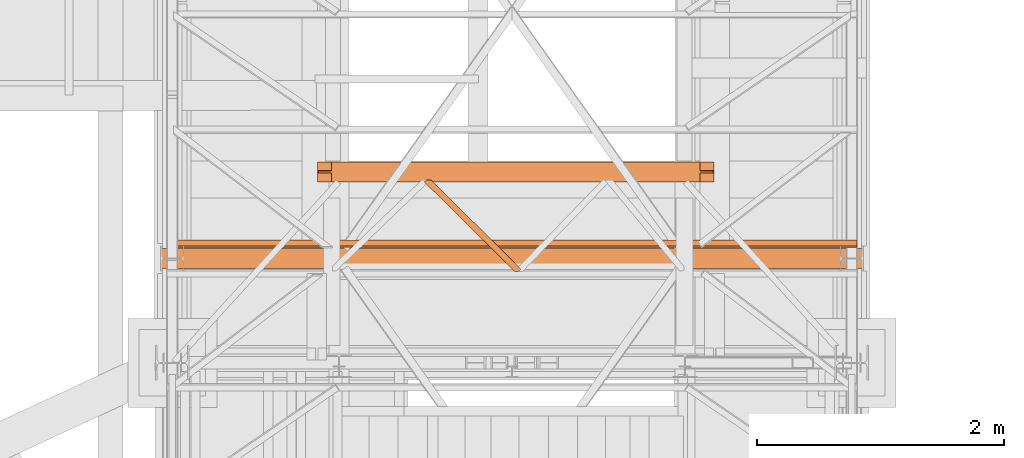
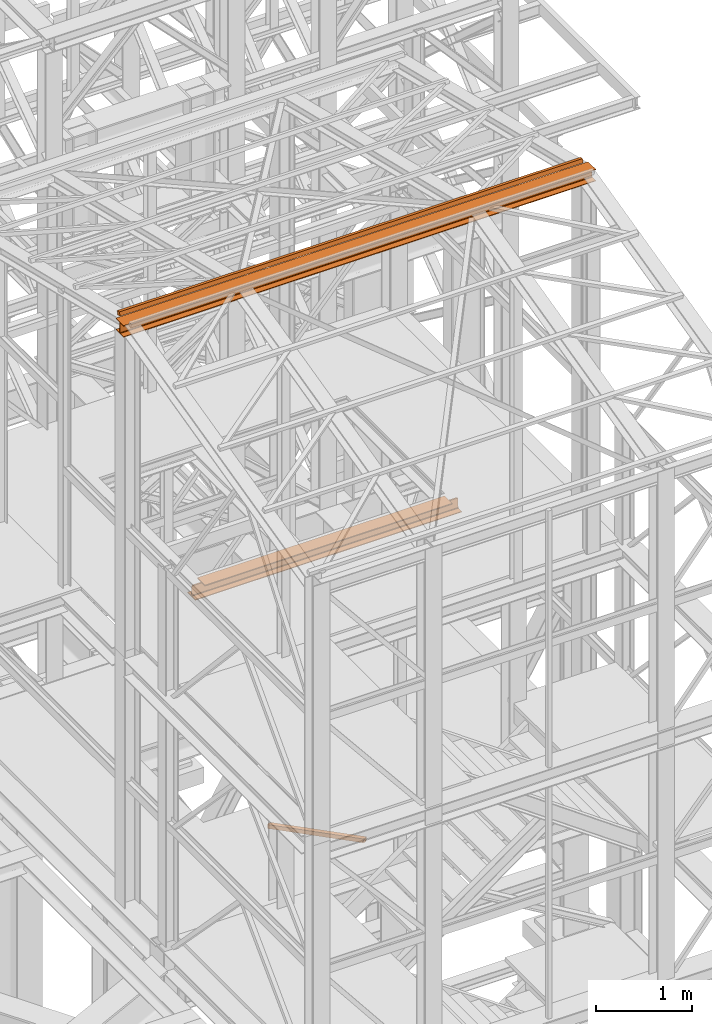
# One storey, part 62 of 208: 4 proxies.
"""IFC2X3 building model written with IfcOpenShell, lengths in millimetres."""

from ifc_helpers import new_model, entity, si_unit, converted_unit, frame, origin, origin_with_axes, place, context, subcontext, project, spatial, faceted_brep, element, save


model = new_model("IFC2X3")

# Units and contexts
model_context = context("Model", 3, precision=1e-05, world=origin())
plan_context = context("Plan", 3, precision=1e-05, world=origin())
body_context = subcontext(model_context, "Body", "Model", "MODEL_VIEW")
ifc_project = project(units=[si_unit("LENGTHUNIT", "METRE", prefix="MILLI"), converted_unit("PLANEANGLEUNIT", "DEGREE", entity("IfcPlaneAngleMeasure", 0.0174532925199433), si_unit("PLANEANGLEUNIT", "RADIAN"), dimensions=[0, 0, 0, 0, 0, 0, 0]), si_unit("AREAUNIT", "SQUARE_METRE"), si_unit("VOLUMEUNIT", "CUBIC_METRE")], contexts=[model_context, plan_context])

# Building, storey
building_placement = place(None, origin())
building = spatial("IfcBuilding", under=ifc_project, at=building_placement, CompositionType="COMPLEX")
storey_placement = place(building_placement, origin_with_axes())
storey = spatial("IfcBuildingStorey", under=building, at=storey_placement, Name="Geschoss", CompositionType="ELEMENT")

# Proxies
proxy_1_placement = place(storey_placement, frame((2372.004968677677, -20596.8503087619, 8332.989992072577), z_axis=(0.0, 0.0, 1.0), x_axis=(1.0, 0.0, 0.0)))
element("IfcBuildingElementProxy", 1, at=proxy_1_placement, inside=storey, context=body_context, shape_type="Brep", body=[
    faceted_brep([(3212.509999701978, 83.01000568851669, 119.0100101923945), (3212.509999701978, 83.01000568851669, 24.01000393390677), (3212.509999701978, 84.56379586666662, 16.24682677745841), (3212.509999701978, 90.24683052509863, 10.5637921190264), (3212.509999701978, 98.01000675022442, 9.010003337860326), (3212.509999701978, 160.0100113248809, 9.010003337860326), (3212.509999701978, 160.0100113248809, 0.01000000000021828), (3212.509999701978, 0.00999999999839929, 0.01000000000021828), (3212.509999701978, 0.00999999999839929, 9.010003337860326), (3212.509999701978, 62.01000457465489, 9.010003337860326), (3212.509999701978, 69.77318079978068, 10.5637921190264), (3212.509999701978, 75.45621545821268, 16.24682677745841), (3212.509999701978, 77.01000563636262, 24.01000393390677), (3212.509999701978, 77.01000563636262, 119.0100101923945), (3096.259995082618, 0.00999999999839929, 152.0100100135805), (116.2600046193611, 0.01000000000203727, 152.0100100135805), (116.2600046193611, 160.0100113248845, 152.0100100135805), (3096.259995082618, 160.0100113248809, 152.0100100135805), (3096.259995082618, 160.0100113248809, 152.0100100135805), (116.2600046193611, 160.0100113248845, 152.0100100135805), (116.2600046193611, 160.0100113248845, 143.0100066757204), (3096.259995082618, 160.0100113248809, 143.0100066757204), (3096.259995082618, 160.0100113248809, 143.0100066757204), (116.2600046193611, 160.0100113248845, 143.0100066757204), (116.2600046193611, 98.01000675022806, 143.0100066757204), (3096.259995082618, 98.01000675022442, 143.0100066757204), (3096.259995082618, 98.01000675022442, 143.0100066757204), (116.2600046193611, 98.01000675022806, 143.0100066757204), (116.2600046193611, 90.24683052510227, 141.4562178945544), (3096.259995082618, 90.24683052509863, 141.4562178945544), (3096.259995082618, 90.24683052509863, 141.4562178945544), (116.2600046193611, 90.24683052510227, 141.4562178945544), (116.2600046193611, 88.80062067717517, 140.0100080466273), (21.01000157952421, 88.80062067717517, 140.0100080466273), (10.14155560940617, 86.6253193637749, 137.834706733227), (8.080032594925797, 84.56379586667026, 135.7731832361224), (3204.439967107053, 84.56379586666662, 135.7731832361224), (3202.378444092573, 86.62531936377127, 137.834706733227), (3191.509998122455, 88.80062067717154, 140.0100080466273), (3096.259995082618, 88.80062067717154, 140.0100080466273), (3204.439967107053, 84.56379586666662, 135.7731832361224), (8.080032594925797, 84.56379586667026, 135.7731832361224), (2.185305970014269, 83.38397287828047, 129.87845523119), (1.811338905195044, 83.01000568852032, 128.0100098049643), (3210.708660796785, 83.01000568851669, 128.0100098049643), (3210.334693731965, 83.38397287828047, 129.87845523119), (3212.509999701978, 83.01000568851669, 24.01000393390677), (3212.509999701978, 83.01000568851669, 119.0100101923945), (3210.708660796785, 83.01000568851669, 128.0100098049643), (1.811338905195044, 83.01000568852032, 128.0100098049643), (0.01000000000203727, 83.01000568852032, 119.0100101923945), (0.01000000000203727, 83.01000568852032, 24.01000393390677), (3212.509999701978, 84.56379586666662, 16.24682677745841), (3212.509999701978, 83.01000568851669, 24.01000393390677), (0.01000000000203727, 83.01000568852032, 24.01000393390677), (0.01000000000203727, 84.56379586667026, 16.24682677745841), (3212.509999701978, 90.24683052509863, 10.5637921190264), (3212.509999701978, 84.56379586666662, 16.24682677745841), (0.01000000000203727, 84.56379586667026, 16.24682677745841), (0.01000000000203727, 90.24683052510227, 10.5637921190264), (3212.509999701978, 98.01000675022442, 9.010003337860326), (3212.509999701978, 90.24683052509863, 10.5637921190264), (0.01000000000203727, 90.24683052510227, 10.5637921190264), (0.01000000000203727, 98.01000675022806, 9.010003337860326), (3212.509999701978, 160.0100113248809, 9.010003337860326), (3212.509999701978, 98.01000675022442, 9.010003337860326), (0.01000000000203727, 98.01000675022806, 9.010003337860326), (0.01000000000203727, 160.0100113248845, 9.010003337860326), (3212.509999701978, 160.0100113248809, 0.01000000000021828), (3212.509999701978, 160.0100113248809, 9.010003337860326), (0.01000000000203727, 160.0100113248845, 9.010003337860326), (0.01000000000203727, 160.0100113248845, 0.01000000000021828), (3212.509999701978, 0.00999999999839929, 0.01000000000021828), (3212.509999701978, 160.0100113248809, 0.01000000000021828), (0.01000000000203727, 160.0100113248845, 0.01000000000021828), (0.01000000000021828, 0.01000000000203727, 0.01000000000021828), (3212.509999701978, 0.00999999999839929, 9.010003337860326), (3212.509999701978, 0.00999999999839929, 0.01000000000021828), (0.01000000000021828, 0.01000000000203727, 0.01000000000021828), (0.01000000000203727, 0.01000000000203727, 9.010003337860326), (3212.509999701978, 62.01000457465489, 9.010003337860326), (3212.509999701978, 0.00999999999839929, 9.010003337860326), (0.01000000000203727, 0.01000000000203727, 9.010003337860326), (0.01000000000203727, 62.01000457465852, 9.010003337860326), (3212.509999701978, 69.77318079978068, 10.5637921190264), (3212.509999701978, 62.01000457465489, 9.010003337860326), (0.01000000000203727, 62.01000457465852, 9.010003337860326), (0.01000000000203727, 69.77318079978431, 10.5637921190264), (3212.509999701978, 75.45621545821268, 16.24682677745841), (3212.509999701978, 69.77318079978068, 10.5637921190264), (0.01000000000203727, 69.77318079978431, 10.5637921190264), (0.01000000000203727, 75.45621545821632, 16.24682677745841), (3212.509999701978, 77.01000563636262, 24.01000393390677), (3212.509999701978, 75.45621545821268, 16.24682677745841), (0.01000000000203727, 75.45621545821632, 16.24682677745841), (0.01000000000203727, 77.01000563636626, 24.01000393390677), (3212.509999701978, 77.01000563636262, 119.0100101923945), (3212.509999701978, 77.01000563636262, 24.01000393390677), (0.01000000000203727, 77.01000563636626, 24.01000393390677), (0.01000000000203727, 77.01000563636626, 119.0100101923945), (1.811338905195044, 77.01000563636626, 128.0100098049643), (3210.708660796784, 77.01000563636262, 128.0100098049643), (3210.708660796784, 77.01000563636262, 128.0100098049643), (1.811338905195044, 77.01000563636626, 128.0100098049643), (2.185305970014269, 76.63603844660247, 129.87845523119), (8.080032594926706, 75.45621545821632, 135.7731832361224), (3204.439967107053, 75.45621545821268, 135.7731832361224), (3210.334693731965, 76.63603844660247, 129.87845523119), (3204.439967107053, 75.45621545821268, 135.7731832361224), (8.080032594926706, 75.45621545821632, 135.7731832361224), (10.14155560940617, 73.39469196110804, 137.834706733227), (21.01000157952421, 71.21939064770777, 140.0100080466273), (116.2600046193611, 71.21939064770777, 140.0100080466273), (116.2600046193611, 69.77318079978431, 141.4562178945544), (3096.259995082618, 69.77318079978068, 141.4562178945544), (3096.259995082618, 71.21939064770777, 140.0100080466273), (3191.509998122455, 71.21939064770777, 140.0100080466273), (3202.378444092573, 73.39469196110804, 137.834706733227), (3096.259995082618, 69.77318079978068, 141.4562178945544), (116.2600046193611, 69.77318079978431, 141.4562178945544), (116.2600046193611, 62.01000457465852, 143.0100066757204), (3096.259995082618, 62.01000457465489, 143.0100066757204), (3096.259995082618, 62.01000457465489, 143.0100066757204), (116.2600046193611, 62.01000457465852, 143.0100066757204), (116.2600046193611, 0.01000000000203727, 143.0100066757204), (3096.259995082618, 0.00999999999839929, 143.0100066757204), (3096.259995082618, 0.00999999999839929, 143.0100066757204), (116.2600046193611, 0.01000000000203727, 143.0100066757204), (116.2600046193611, 0.01000000000203727, 152.0100100135805), (3096.259995082618, 0.00999999999839929, 152.0100100135805), (0.01000000000203727, 77.01000563636626, 119.0100101923945), (0.01000000000203727, 77.01000563636626, 24.01000393390677), (0.01000000000203727, 75.45621545821632, 16.24682677745841), (0.01000000000203727, 69.77318079978431, 10.5637921190264), (0.01000000000203727, 62.01000457465852, 9.010003337860326), (0.01000000000203727, 0.01000000000203727, 9.010003337860326), (0.01000000000021828, 0.01000000000203727, 0.01000000000021828), (0.01000000000203727, 160.0100113248845, 0.01000000000021828), (0.01000000000203727, 160.0100113248845, 9.010003337860326), (0.01000000000203727, 98.01000675022806, 9.010003337860326), (0.01000000000203727, 90.24683052510227, 10.5637921190264), (0.01000000000203727, 84.56379586667026, 16.24682677745841), (0.01000000000203727, 83.01000568852032, 24.01000393390677), (0.01000000000203727, 83.01000568852032, 119.0100101923945), (3096.259995082618, 160.0100113248809, 152.0100100135805), (3096.259995082618, 160.0100113248809, 143.0100066757204), (3096.259995082618, 98.01000675022442, 143.0100066757204), (3096.259995082618, 90.24683052509863, 141.4562178945544), (3096.259995082618, 88.80062067717154, 140.0100080466273), (3096.259995082618, 71.21939064770777, 140.0100080466273), (3096.259995082618, 69.77318079978068, 141.4562178945544), (3096.259995082618, 62.01000457465489, 143.0100066757204), (3096.259995082618, 0.00999999999839929, 143.0100066757204), (3096.259995082618, 0.00999999999839929, 152.0100100135805), (3096.259995082618, 88.80062067717154, 140.0100080466273), (3191.509998122455, 88.80062067717154, 140.0100080466273), (3191.509998122455, 71.21939064770777, 140.0100080466273), (3096.259995082618, 71.21939064770777, 140.0100080466273), (3191.509998122455, 88.80062067717154, 140.0100080466273), (3202.378444092573, 86.62531936377127, 137.834706733227), (3202.378444092573, 73.39469196110804, 137.834706733227), (3191.509998122455, 71.21939064770777, 140.0100080466273), (3202.378444092573, 86.62531936377127, 137.834706733227), (3204.439967107053, 84.56379586666662, 135.7731832361224), (3210.334693731965, 83.38397287828047, 129.87845523119), (3210.334693731965, 76.63603844660247, 129.87845523119), (3204.439967107053, 75.45621545821268, 135.7731832361224), (3202.378444092573, 73.39469196110804, 137.834706733227), (3210.334693731965, 83.38397287828047, 129.87845523119), (3210.708660796785, 83.01000568851669, 128.0100098049643), (3212.509999701978, 83.01000568851669, 119.0100101923945), (3212.509999701978, 77.01000563636262, 119.0100101923945), (3210.708660796784, 77.01000563636262, 128.0100098049643), (3210.334693731965, 76.63603844660247, 129.87845523119), (0.01000000000203727, 83.01000568852032, 119.0100101923945), (1.811338905195044, 83.01000568852032, 128.0100098049643), (2.185305970014269, 83.38397287828047, 129.87845523119), (2.185305970014269, 76.63603844660247, 129.87845523119), (1.811338905195044, 77.01000563636626, 128.0100098049643), (0.01000000000203727, 77.01000563636626, 119.0100101923945), (2.185305970014269, 83.38397287828047, 129.87845523119), (8.080032594925797, 84.56379586667026, 135.7731832361224), (10.14155560940617, 86.6253193637749, 137.834706733227), (10.14155560940617, 73.39469196110804, 137.834706733227), (8.080032594926706, 75.45621545821632, 135.7731832361224), (2.185305970014269, 76.63603844660247, 129.87845523119), (10.14155560940617, 86.6253193637749, 137.834706733227), (21.01000157952421, 88.80062067717517, 140.0100080466273), (21.01000157952421, 71.21939064770777, 140.0100080466273), (10.14155560940617, 73.39469196110804, 137.834706733227), (21.01000157952421, 88.80062067717517, 140.0100080466273), (116.2600046193611, 88.80062067717517, 140.0100080466273), (116.2600046193611, 71.21939064770777, 140.0100080466273), (21.01000157952421, 71.21939064770777, 140.0100080466273), (116.2600046193611, 88.80062067717517, 140.0100080466273), (116.2600046193611, 90.24683052510227, 141.4562178945544), (116.2600046193611, 98.01000675022806, 143.0100066757204), (116.2600046193611, 160.0100113248845, 143.0100066757204), (116.2600046193611, 160.0100113248845, 152.0100100135805), (116.2600046193611, 0.01000000000203727, 152.0100100135805), (116.2600046193611, 0.01000000000203727, 143.0100066757204), (116.2600046193611, 62.01000457465852, 143.0100066757204), (116.2600046193611, 69.77318079978431, 141.4562178945544), (116.2600046193611, 71.21939064770777, 140.0100080466273)], [[[0, 1, 2, 3, 4, 5, 6, 7, 8, 9, 10, 11, 12, 13]], [[14, 15, 16, 17]], [[18, 19, 20, 21]], [[22, 23, 24, 25]], [[26, 27, 28, 29]], [[30, 31, 32, 33, 34, 35, 36, 37, 38, 39]], [[40, 41, 42, 43, 44, 45]], [[46, 47, 48, 49, 50, 51]], [[52, 53, 54, 55]], [[56, 57, 58, 59]], [[60, 61, 62, 63]], [[64, 65, 66, 67]], [[68, 69, 70, 71]], [[72, 73, 74, 75]], [[76, 77, 78, 79]], [[80, 81, 82, 83]], [[84, 85, 86, 87]], [[88, 89, 90, 91]], [[92, 93, 94, 95]], [[96, 97, 98, 99, 100, 101]], [[102, 103, 104, 105, 106, 107]], [[108, 109, 110, 111, 112, 113, 114, 115, 116, 117]], [[118, 119, 120, 121]], [[122, 123, 124, 125]], [[126, 127, 128, 129]], [[130, 131, 132, 133, 134, 135, 136, 137, 138, 139, 140, 141, 142, 143]], [[144, 145, 146, 147, 148, 149, 150, 151, 152, 153]], [[154, 155, 156, 157]], [[158, 159, 160, 161]], [[162, 163, 164, 165, 166, 167]], [[168, 169, 170, 171, 172, 173]], [[174, 175, 176, 177, 178, 179]], [[180, 181, 182, 183, 184, 185]], [[186, 187, 188, 189]], [[190, 191, 192, 193]], [[194, 195, 196, 197, 198, 199, 200, 201, 202, 203]]], orient=[[False], [False], [False], [False], [False], [False], [False], [False], [False], [False], [False], [False], [False], [False], [False], [False], [False], [False], [False], [False], [False], [False], [False], [False], [False], [False], [False], [False], [False], [False], [False], [False], [False], [False], [False], [False]]),
])
proxy_2_placement = place(storey_placement, frame((1157.254971121463, -21129.0126483825, 12689.02228571494), z_axis=(0.0, 0.0, 1.0), x_axis=(1.0, 0.0, 0.0)))
element("IfcBuildingElementProxy", 2, at=proxy_2_placement, inside=storey, context=body_context, shape_type="Brep", body=[
    faceted_brep([(5582.010002264973, 11.80406569683692, 60.39315927079588), (5582.010002264973, 60.39315927079224, 48.59909357395736), (5582.010002264973, 48.59909357395372, 0.01000000000021828), (5582.010002264973, 0.00999999999839929, 11.80406569683873), (0.01000000000021828, 60.39315927079224, 48.59909357395736), (0.01000000000021828, 11.80406569683692, 60.39315927079588), (0.01000000000021828, 0.00999999999839929, 11.80406569683873), (0.01000000000021828, 48.59909357395372, 0.01000000000021828), (5582.010002264973, 60.39315927079224, 48.59909357395736), (5582.010002264973, 11.80406569683692, 60.39315927079588), (0.01000000000021828, 11.80406569683692, 60.39315927079588), (0.01000000000021828, 60.39315927079224, 48.59909357395736), (5582.010002264973, 48.59909357395372, 0.01000000000021828), (5582.010002264973, 60.39315927079224, 48.59909357395736), (0.01000000000021828, 60.39315927079224, 48.59909357395736), (0.01000000000021828, 48.59909357395372, 0.01000000000021828), (5582.010002264973, 0.00999999999839929, 11.80406569683873), (5582.010002264973, 48.59909357395372, 0.01000000000021828), (0.01000000000021828, 48.59909357395372, 0.01000000000021828), (0.01000000000021828, 0.00999999999839929, 11.80406569683873), (5582.010002264973, 11.80406569683692, 60.39315927079588), (5582.010002264973, 0.00999999999839929, 11.80406569683873), (0.01000000000021828, 0.00999999999839929, 11.80406569683873), (0.01000000000021828, 11.80406569683692, 60.39315927079588)], [[[0, 1, 2, 3]], [[4, 5, 6, 7]], [[8, 9, 10, 11]], [[12, 13, 14, 15]], [[16, 17, 18, 19]], [[20, 21, 22, 23]]], orient=[[False], [False], [False], [False], [False], [False]]),
])
proxy_3_placement = place(storey_placement, frame((1103.25496227017, -21297.57439598033, 12550.89453781338), z_axis=(0.0, 0.0, 1.0), x_axis=(1.0, 0.0, 0.0)))
element("IfcBuildingElementProxy", 3, at=proxy_3_placement, inside=storey, context=body_context, shape_type="Brep", body=[
    faceted_brep([(5690.010012516976, 0.00999999999839929, 152.0100100135805), (5690.010012516976, 160.0100113248809, 152.0100100135805), (5690.010012516976, 160.0100113248809, 143.0100066757204), (5690.010012516976, 98.01000675022442, 143.0100066757204), (5690.010012516976, 90.24683052509863, 141.4562178945544), (5690.010012516976, 84.56379586666662, 135.7731832361224), (5690.010012516976, 83.01000568851669, 128.0100098049643), (5690.010012516976, 83.01000568851669, 24.01000393390677), (5690.010012516976, 84.56379586666662, 16.24682677745841), (5690.010012516976, 90.24683052509863, 10.5637921190264), (5690.010012516976, 98.01000675022442, 9.010003337860326), (5690.010012516976, 160.0100113248809, 9.010003337860326), (5690.010012516976, 160.0100113248809, 0.01000000000021828), (5690.010012516976, 0.00999999999839929, 0.01000000000021828), (5690.010012516976, 0.00999999999839929, 9.010003337860326), (5690.010012516976, 62.01000457465489, 9.010003337860326), (5690.010012516976, 69.77318079978068, 10.5637921190264), (5690.010012516976, 75.45621545821268, 16.24682677745841), (5690.010012516976, 77.01000563636262, 24.01000393390677), (5690.010012516976, 77.01000563636262, 128.0100098049643), (5690.010012516976, 75.45621545821268, 135.7731832361224), (5690.010012516976, 69.77318079978068, 141.4562178945544), (5690.010012516976, 62.01000457465489, 143.0100066757204), (5690.010012516976, 0.00999999999839929, 143.0100066757204), (5690.010012516976, 160.0100113248809, 152.0100100135805), (5690.010012516976, 0.00999999999839929, 152.0100100135805), (0.01000000000021828, 0.00999999999839929, 152.0100100135805), (0.01000000000021828, 160.0100113248809, 152.0100100135805), (5690.010012516976, 160.0100113248809, 143.0100066757204), (5690.010012516976, 160.0100113248809, 152.0100100135805), (0.01000000000021828, 160.0100113248809, 152.0100100135805), (0.01000000000021828, 160.0100113248809, 143.0100066757204), (5690.010012516976, 98.01000675022442, 143.0100066757204), (5690.010012516976, 160.0100113248809, 143.0100066757204), (0.01000000000021828, 160.0100113248809, 143.0100066757204), (0.01000000000021828, 98.01000675022442, 143.0100066757204), (5690.010012516976, 90.24683052509863, 141.4562178945544), (5690.010012516976, 98.01000675022442, 143.0100066757204), (0.01000000000021828, 98.01000675022442, 143.0100066757204), (0.01000000000021828, 90.24683052509863, 141.4562178945544), (5690.010012516976, 84.56379586666662, 135.7731832361224), (5690.010012516976, 90.24683052509863, 141.4562178945544), (0.01000000000021828, 90.24683052509863, 141.4562178945544), (0.01000000000021828, 84.56379586666662, 135.7731832361224), (5690.010012516976, 83.01000568851669, 128.0100098049643), (5690.010012516976, 84.56379586666662, 135.7731832361224), (0.01000000000021828, 84.56379586666662, 135.7731832361224), (0.01000000000021828, 83.01000568851669, 128.0100098049643), (5690.010012516976, 83.01000568851669, 24.01000393390677), (5690.010012516976, 83.01000568851669, 128.0100098049643), (0.01000000000021828, 83.01000568851669, 128.0100098049643), (0.01000000000021828, 83.01000568851669, 24.01000393390677), (5690.010012516976, 84.56379586666662, 16.24682677745841), (5690.010012516976, 83.01000568851669, 24.01000393390677), (0.01000000000021828, 83.01000568851669, 24.01000393390677), (0.01000000000021828, 84.56379586666662, 16.24682677745841), (5690.010012516976, 90.24683052509863, 10.5637921190264), (5690.010012516976, 84.56379586666662, 16.24682677745841), (0.01000000000021828, 84.56379586666662, 16.24682677745841), (0.01000000000021828, 90.24683052509863, 10.5637921190264), (5690.010012516976, 98.01000675022442, 9.010003337860326), (5690.010012516976, 90.24683052509863, 10.5637921190264), (0.01000000000021828, 90.24683052509863, 10.5637921190264), (0.01000000000021828, 98.01000675022442, 9.010003337860326), (5690.010012516976, 160.0100113248809, 9.010003337860326), (5690.010012516976, 98.01000675022442, 9.010003337860326), (0.01000000000021828, 98.01000675022442, 9.010003337860326), (0.01000000000021828, 160.0100113248809, 9.010003337860326), (5690.010012516976, 160.0100113248809, 0.01000000000021828), (5690.010012516976, 160.0100113248809, 9.010003337860326), (0.01000000000021828, 160.0100113248809, 9.010003337860326), (0.01000000000021828, 160.0100113248809, 0.01000000000021828), (5690.010012516976, 0.00999999999839929, 0.01000000000021828), (5690.010012516976, 160.0100113248809, 0.01000000000021828), (0.01000000000021828, 160.0100113248809, 0.01000000000021828), (0.01000000000021828, 0.00999999999839929, 0.01000000000021828), (5690.010012516976, 0.00999999999839929, 9.010003337860326), (5690.010012516976, 0.00999999999839929, 0.01000000000021828), (0.01000000000021828, 0.00999999999839929, 0.01000000000021828), (0.01000000000021828, 0.00999999999839929, 9.010003337860326), (5690.010012516976, 62.01000457465489, 9.010003337860326), (5690.010012516976, 0.00999999999839929, 9.010003337860326), (0.01000000000021828, 0.00999999999839929, 9.010003337860326), (0.01000000000021828, 62.01000457465489, 9.010003337860326), (5690.010012516976, 69.77318079978068, 10.5637921190264), (5690.010012516976, 62.01000457465489, 9.010003337860326), (0.01000000000021828, 62.01000457465489, 9.010003337860326), (0.01000000000021828, 69.77318079978068, 10.5637921190264), (5690.010012516976, 75.45621545821268, 16.24682677745841), (5690.010012516976, 69.77318079978068, 10.5637921190264), (0.01000000000021828, 69.77318079978068, 10.5637921190264), (0.01000000000021828, 75.45621545821268, 16.24682677745841), (5690.010012516976, 77.01000563636262, 24.01000393390677), (5690.010012516976, 75.45621545821268, 16.24682677745841), (0.01000000000021828, 75.45621545821268, 16.24682677745841), (0.01000000000021828, 77.01000563636262, 24.01000393390677), (5690.010012516976, 77.01000563636262, 128.0100098049643), (5690.010012516976, 77.01000563636262, 24.01000393390677), (0.01000000000021828, 77.01000563636262, 24.01000393390677), (0.01000000000021828, 77.01000563636262, 128.0100098049643), (5690.010012516976, 75.45621545821268, 135.7731832361224), (5690.010012516976, 77.01000563636262, 128.0100098049643), (0.01000000000021828, 77.01000563636262, 128.0100098049643), (0.01000000000021828, 75.45621545821268, 135.7731832361224), (5690.010012516976, 69.77318079978068, 141.4562178945544), (5690.010012516976, 75.45621545821268, 135.7731832361224), (0.01000000000021828, 75.45621545821268, 135.7731832361224), (0.01000000000021828, 69.77318079978068, 141.4562178945544), (5690.010012516976, 62.01000457465489, 143.0100066757204), (5690.010012516976, 69.77318079978068, 141.4562178945544), (0.01000000000021828, 69.77318079978068, 141.4562178945544), (0.01000000000021828, 62.01000457465489, 143.0100066757204), (5690.010012516976, 0.00999999999839929, 143.0100066757204), (5690.010012516976, 62.01000457465489, 143.0100066757204), (0.01000000000021828, 62.01000457465489, 143.0100066757204), (0.01000000000021828, 0.00999999999839929, 143.0100066757204), (5690.010012516976, 0.00999999999839929, 152.0100100135805), (5690.010012516976, 0.00999999999839929, 143.0100066757204), (0.01000000000021828, 0.00999999999839929, 143.0100066757204), (0.01000000000021828, 0.00999999999839929, 152.0100100135805), (0.01000000000021828, 0.00999999999839929, 152.0100100135805), (0.01000000000021828, 0.00999999999839929, 143.0100066757204), (0.01000000000021828, 62.01000457465489, 143.0100066757204), (0.01000000000021828, 69.77318079978068, 141.4562178945544), (0.01000000000021828, 75.45621545821268, 135.7731832361224), (0.01000000000021828, 77.01000563636262, 128.0100098049643), (0.01000000000021828, 77.01000563636262, 24.01000393390677), (0.01000000000021828, 75.45621545821268, 16.24682677745841), (0.01000000000021828, 69.77318079978068, 10.5637921190264), (0.01000000000021828, 62.01000457465489, 9.010003337860326), (0.01000000000021828, 0.00999999999839929, 9.010003337860326), (0.01000000000021828, 0.00999999999839929, 0.01000000000021828), (0.01000000000021828, 160.0100113248809, 0.01000000000021828), (0.01000000000021828, 160.0100113248809, 9.010003337860326), (0.01000000000021828, 98.01000675022442, 9.010003337860326), (0.01000000000021828, 90.24683052509863, 10.5637921190264), (0.01000000000021828, 84.56379586666662, 16.24682677745841), (0.01000000000021828, 83.01000568851669, 24.01000393390677), (0.01000000000021828, 83.01000568851669, 128.0100098049643), (0.01000000000021828, 84.56379586666662, 135.7731832361224), (0.01000000000021828, 90.24683052509863, 141.4562178945544), (0.01000000000021828, 98.01000675022442, 143.0100066757204), (0.01000000000021828, 160.0100113248809, 143.0100066757204), (0.01000000000021828, 160.0100113248809, 152.0100100135805)], [[[0, 1, 2, 3, 4, 5, 6, 7, 8, 9, 10, 11, 12, 13, 14, 15, 16, 17, 18, 19, 20, 21, 22, 23]], [[24, 25, 26, 27]], [[28, 29, 30, 31]], [[32, 33, 34, 35]], [[36, 37, 38, 39]], [[40, 41, 42, 43]], [[44, 45, 46, 47]], [[48, 49, 50, 51]], [[52, 53, 54, 55]], [[56, 57, 58, 59]], [[60, 61, 62, 63]], [[64, 65, 66, 67]], [[68, 69, 70, 71]], [[72, 73, 74, 75]], [[76, 77, 78, 79]], [[80, 81, 82, 83]], [[84, 85, 86, 87]], [[88, 89, 90, 91]], [[92, 93, 94, 95]], [[96, 97, 98, 99]], [[100, 101, 102, 103]], [[104, 105, 106, 107]], [[108, 109, 110, 111]], [[112, 113, 114, 115]], [[116, 117, 118, 119]], [[120, 121, 122, 123, 124, 125, 126, 127, 128, 129, 130, 131, 132, 133, 134, 135, 136, 137, 138, 139, 140, 141, 142, 143]]], orient=[[False], [False], [False], [False], [False], [False], [False], [False], [False], [False], [False], [False], [False], [False], [False], [False], [False], [False], [False], [False], [False], [False], [False], [False], [False], [False]]),
])
proxy_4_placement = place(storey_placement, frame((3238.199636538295, -21323.87439017521, 5124.989999999998), z_axis=(0.0, 0.0, 1.0), x_axis=(1.0, 0.0, 0.0)))
element("IfcBuildingElementProxy", 4, at=proxy_4_placement, inside=storey, context=body_context, shape_type="Brep", body=[
    faceted_brep([(733.62063729886, 0.01000000000203727, 0.01000000000021828), (0.01000000000021828, 726.1340606672748, 0.01000000000021828), (0.01000000000021828, 726.1340606672748, 50.01000000000022), (733.6206372988609, 0.01000000000203727, 50.01000000000022), (759.6388819514241, 0.01000000000203727, 0.01000000000021828), (784.8981974364879, 18.80894162131153, 0.01000000000021828), (56.46338220809412, 739.8100000473169, 0.01000000000021828), (18.38576148241555, 739.8100000473169, 0.01000000000021828), (0.01000000000021828, 726.1340606672748, 0.01000000000021828), (733.62063729886, 0.01000000000203727, 0.01000000000021828), (784.8981974364879, 18.80894162131153, 0.01000000000021828), (784.8981974364879, 18.80894162131153, 50.01000000000022), (56.46338220809412, 739.8100000473169, 50.01000000000022), (56.46338220809412, 739.8100000473169, 0.01000000000021828), (784.8981974364879, 18.80894162131153, 50.01000000000022), (759.6388819514241, 0.01000000000203727, 50.01000000000022), (733.6206372988609, 0.01000000000203727, 50.01000000000022), (0.01000000000021828, 726.1340606672748, 50.01000000000022), (18.38576148241555, 739.8100000473169, 50.01000000000022), (56.46338220809412, 739.8100000473169, 50.01000000000022), (759.6388819514241, 0.01000000000203727, 50.01000000000022), (784.8981974364879, 18.80894162131153, 50.01000000000022), (784.8981974364879, 18.80894162131153, 0.01000000000021828), (759.6388819514241, 0.01000000000203727, 0.01000000000021828), (759.638881951425, 0.01000000000567525, 4.010000000000218), (781.6893443484269, 16.42079132050276, 4.010000000000218), (781.6893443484269, 16.42079132050276, 46.01000000000022), (759.638881951425, 0.01000000000567525, 46.01000000000022), (0.01000000000021828, 726.1340606672748, 50.01000000000022), (0.01000000000021828, 726.1340606672748, 0.01000000000021828), (18.38576148241555, 739.8100000473169, 0.01000000000021828), (18.38576148241555, 739.8100000473132, 4.010000000000218), (3.218853088061223, 728.5222109680799, 4.010000000000218), (3.218853088061223, 728.5222109680799, 46.01000000000022), (18.38576148241555, 739.8100000473132, 46.01000000000022), (18.38576148241555, 739.8100000473169, 50.01000000000022), (739.2422632986618, 0.01000000000203727, 46.01000000000022), (3.218853088061223, 728.5222109680799, 46.01000000000022), (3.218853088061223, 728.5222109680799, 4.010000000000218), (739.2422632986618, 0.01000000000203727, 4.010000000000218), (739.2422632986618, 0.01000000000203727, 4.010000000000218), (3.218853088061223, 728.5222109680799, 4.010000000000218), (18.38576148241555, 739.8100000473132, 4.010000000000218), (50.8417562082941, 739.8100000473169, 4.010000000000218), (781.6893443484269, 16.42079132050276, 4.010000000000218), (759.638881951425, 0.01000000000567525, 4.010000000000218), (781.6893443484269, 16.42079132050276, 4.010000000000218), (50.8417562082941, 739.8100000473169, 4.010000000000218), (50.84175620829319, 739.8100000473169, 46.00999999999931), (781.6893443484269, 16.42079132050276, 46.01000000000022), (781.6893443484269, 16.42079132050276, 46.01000000000022), (50.84175620829319, 739.8100000473169, 46.00999999999931), (18.38576148241555, 739.8100000473132, 46.01000000000022), (3.218853088061223, 728.5222109680799, 46.01000000000022), (739.2422632986618, 0.01000000000203727, 46.01000000000022), (759.638881951425, 0.01000000000567525, 46.01000000000022), (56.46338220809412, 739.8100000473169, 0.01000000000021828), (56.46338220809412, 739.8100000473169, 50.01000000000022), (18.38576148241555, 739.8100000473169, 50.01000000000022), (18.38576148241555, 739.8100000473132, 46.01000000000022), (50.84175620829319, 739.8100000473169, 46.00999999999931), (50.8417562082941, 739.8100000473169, 4.010000000000218), (18.38576148241555, 739.8100000473132, 4.010000000000218), (18.38576148241555, 739.8100000473169, 0.01000000000021828), (733.6206372988609, 0.01000000000203727, 50.01000000000022), (759.6388819514241, 0.01000000000203727, 50.01000000000022), (759.638881951425, 0.01000000000567525, 46.01000000000022), (739.2422632986618, 0.01000000000203727, 46.01000000000022), (739.2422632986618, 0.01000000000203727, 4.010000000000218), (759.638881951425, 0.01000000000567525, 4.010000000000218), (759.6388819514241, 0.01000000000203727, 0.01000000000021828), (733.62063729886, 0.01000000000203727, 0.01000000000021828)], [[[0, 1, 2, 3]], [[4, 5, 6, 7, 8, 9]], [[10, 11, 12, 13]], [[14, 15, 16, 17, 18, 19]], [[20, 21, 22, 23, 24, 25, 26, 27]], [[28, 29, 30, 31, 32, 33, 34, 35]], [[36, 37, 38, 39]], [[40, 41, 42, 43, 44, 45]], [[46, 47, 48, 49]], [[50, 51, 52, 53, 54, 55]], [[56, 57, 58, 59, 60, 61, 62, 63]], [[64, 65, 66, 67, 68, 69, 70, 71]]], orient=[[False], [False], [False], [False], [False], [False], [False], [False], [False], [False], [False], [False]]),
])

save(model, "model.ifc")
